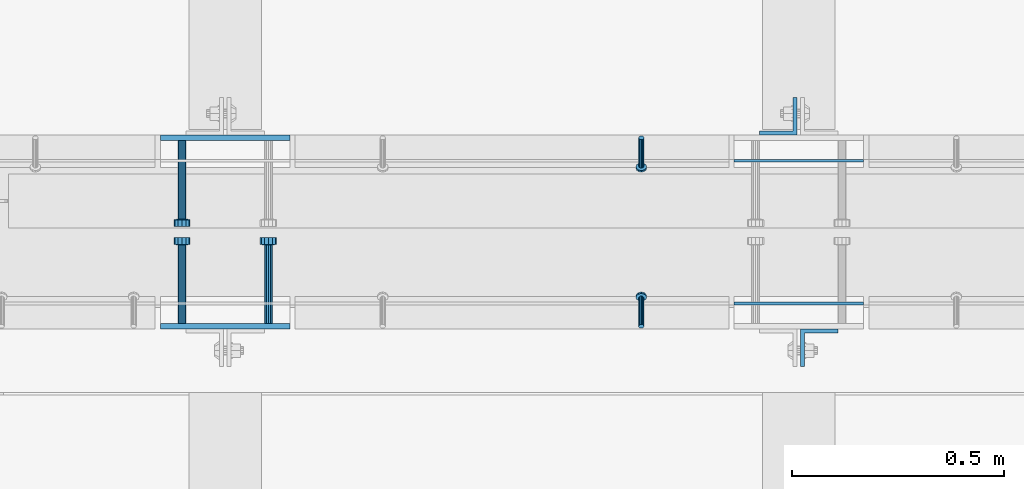
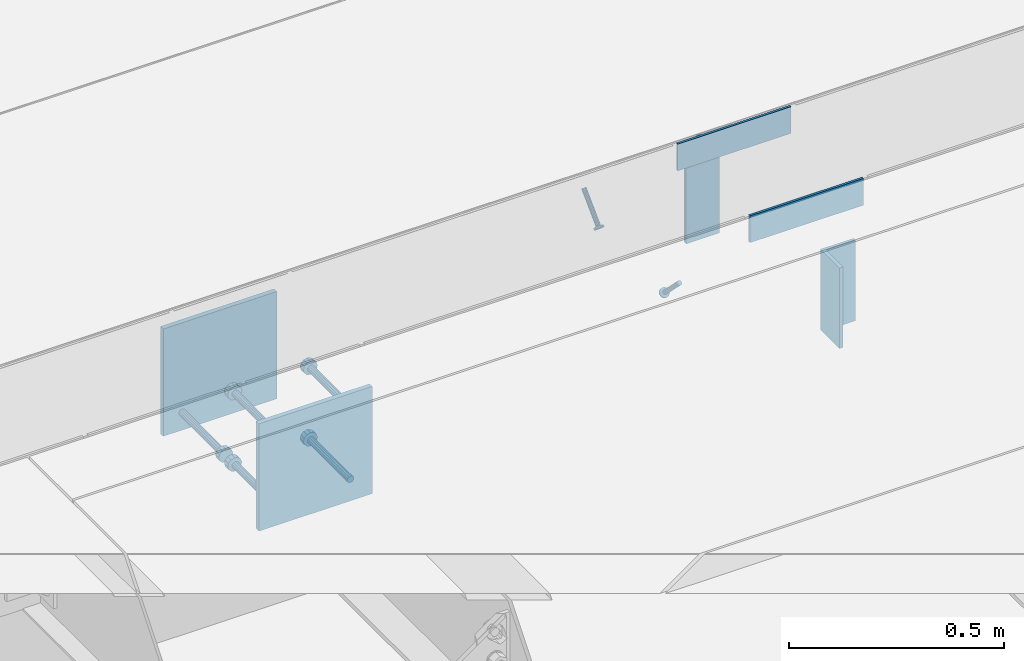
# One storey, part 2010 of 3843: 11 beams, 2 members, 8 elements without a shape of their own.
"""IFC2X3 building model written with IfcOpenShell, lengths in millimetres."""

import ifcopenshell
import ifcopenshell.guid

model = None  # the IFC model being written
_history = None  # IfcOwnerHistory: only IFC2X3 demands one
_inside = {}  # id of a spatial element -> (the spatial element, [elements in it])
_under = {}  # id of a project, library or spatial element -> (it, [spatial elements below it])
_declared = {}  # id of a project -> (the project, [libraries it declares])
_typed = {}  # id of a type object -> (the type object, [elements of that type])
_made_of = {}  # id of a material, layer set ... -> (it, [elements and type objects made of it])


def new_model(schema):
    """Start an empty IFC model of exactly this schema.

    Asked for "IFC4X3", IfcOpenShell would pick the latest addendum, in which some entities
    have other attributes; the version numbers below select the first issue.
    IFC2X3 requires an IfcOwnerHistory on every rooted entity: one is made here for all.
    """
    global model, _history
    if schema == "IFC4X3":
        model = ifcopenshell.file(schema_version=(4, 3, 0, 0))
    else:
        model = ifcopenshell.file(schema=schema)
    _inside.clear()
    _under.clear()
    _declared.clear()
    _typed.clear()
    _made_of.clear()
    _history = None
    if model.schema == "IFC2X3":
        org = make("IfcOrganization", Name="unknown")
        user = make(
            "IfcPersonAndOrganization",
            ThePerson=make("IfcPerson", FamilyName="unknown"),
            TheOrganization=org,
        )
        app = make(
            "IfcApplication",
            ApplicationDeveloper=org,
            Version="unknown",
            ApplicationFullName="unknown",
            ApplicationIdentifier="unknown",
        )
        _history = make(
            "IfcOwnerHistory",
            OwningUser=user,
            OwningApplication=app,
            ChangeAction="ADDED",
            CreationDate=0,
        )
    return model


def make(cls, **values):
    """One entity of the class cls with the attributes given. An attribute that is None is left unset."""
    return model.create_entity(
        cls, **{name: value for name, value in values.items() if value is not None}
    )


def rooted(cls, **values):
    """An entity with a GlobalId (a new one), such as an element, a storey or a relation."""
    return make(cls, GlobalId=ifcopenshell.guid.new(), OwnerHistory=_history, **values)


def si_unit(unit_type, name, prefix=None):
    """IfcSIUnit, for example si_unit("LENGTHUNIT", "METRE", prefix="MILLI")."""
    return make("IfcSIUnit", UnitType=unit_type, Prefix=prefix, Name=name)


def assignment(units):
    """IfcUnitAssignment: the units of a project."""
    return None if units is None else make("IfcUnitAssignment", Units=units)


def point(xyz):
    """IfcCartesianPoint."""
    return None if xyz is None else make("IfcCartesianPoint", Coordinates=xyz)


def direction(xyz):
    """IfcDirection."""
    return None if xyz is None else make("IfcDirection", DirectionRatios=xyz)


def frame(location, z_axis=None, x_axis=None):
    """IfcAxis2Placement3D, a coordinate frame: its origin and axes. An axis left out is left unset."""
    return make(
        "IfcAxis2Placement3D",
        Location=point(location),
        Axis=direction(z_axis),
        RefDirection=direction(x_axis),
    )


def origin_with_axes():
    """The frame at (0, 0, 0) with the z axis (0, 0, 1) and the x axis (1, 0, 0) written out."""
    return frame((0.0, 0.0, 0.0), z_axis=(0.0, 0.0, 1.0), x_axis=(1.0, 0.0, 0.0))


def place(relative_to, where):
    """IfcLocalPlacement: puts the frame where relative to a parent placement (None: the world)."""
    return make(
        "IfcLocalPlacement", PlacementRelTo=relative_to, RelativePlacement=where
    )


def context(
    kind, dimensions, precision=None, world=None, true_north=None, identifier=None
):
    """IfcGeometricRepresentationContext, for example the 3D "Model" context."""
    return make(
        "IfcGeometricRepresentationContext",
        ContextIdentifier=identifier,
        ContextType=kind,
        CoordinateSpaceDimension=dimensions,
        Precision=precision,
        WorldCoordinateSystem=world,
        TrueNorth=true_north,
    )


def subcontext(parent, identifier, kind, view, scale=None):
    """IfcGeometricRepresentationSubContext, for example "Body" below "Model"."""
    return make(
        "IfcGeometricRepresentationSubContext",
        ContextIdentifier=identifier,
        ContextType=kind,
        ParentContext=parent,
        TargetScale=scale,
        TargetView=view,
    )


def project(units=None, contexts=None):
    """IfcProject with its units and contexts."""
    return rooted(
        "IfcProject",
        Name="project",
        RepresentationContexts=contexts,
        UnitsInContext=assignment(units),
    )


def spatial(cls, under=None, at=None, **own):
    """A site, building, storey or space (cls), placed at a placement, below another one or the project."""
    s = rooted(cls, ObjectPlacement=at, **own)
    if under is not None:
        _under.setdefault(under.id(), (under, []))[1].append(s)
    return s


def faces_of(points, faces, orient=None, outer=None):
    """IfcFace entities. A face is a list of loops; a loop is a list of indices into points, from 0.

    orient and outer hold one flag for each loop. By default every Orientation is true, the
    first loop of a face is its IfcFaceOuterBound and the others are IfcFaceBound.
    """
    made = []
    for i, loops in enumerate(faces):
        bounds = []
        for j, loop in enumerate(loops):
            is_outer = j == 0 if outer is None else outer[i][j]
            bounds.append(
                make(
                    "IfcFaceOuterBound" if is_outer else "IfcFaceBound",
                    Bound=make("IfcPolyLoop", Polygon=[points[k] for k in loop]),
                    Orientation=True if orient is None else orient[i][j],
                )
            )
        made.append(make("IfcFace", Bounds=bounds))
    return made


def faceted_brep(points, faces, orient=None, outer=None, voids=None):
    """IfcFacetedBrep: a solid bounded by flat faces; with voids (closed shells), ...WithVoids."""
    shared = [point(p) for p in points]
    hull = make("IfcClosedShell", CfsFaces=faces_of(shared, faces, orient, outer))
    if voids is None:
        return make("IfcFacetedBrep", Outer=hull)
    return make(
        "IfcFacetedBrepWithVoids",
        Outer=hull,
        Voids=[
            make(cls, CfsFaces=faces_of(shared, fs, o, b)) for cls, fs, o, b in voids
        ],
    )


def shape(context_of_items, identifier, shape_type, items):
    """IfcShapeRepresentation: the items that make up one representation, for example the "Body"."""
    return make(
        "IfcShapeRepresentation",
        ContextOfItems=context_of_items,
        RepresentationIdentifier=identifier,
        RepresentationType=shape_type,
        Items=items,
    )


def material(Name=None, Category=None):
    """IfcMaterial."""
    return make("IfcMaterial", Name=Name, Category=Category)


def made_of(thing, what):
    """Note that an element or type object is made of a material, layer set ...; save() writes the relation."""
    if what is not None:
        _made_of.setdefault(what.id(), (what, []))[1].append(thing)
    return thing


def type_object(cls, material=None, **own):
    """A type object (cls), such as IfcWallType, which elements share."""
    return made_of(rooted(cls, **own), material)


def element(
    cls,
    number,
    at=None,
    inside=None,
    cuts=None,
    type_object=None,
    material=None,
    context=None,
    identifier="Body",
    shape_type=None,
    held_by="IfcProductDefinitionShape",
    body=None,
    shapes=None,
    **own,
):
    """One element of the class cls, such as IfcWall. Its Tag is "e" and its number.

    at: its placement. inside: the storey or other place that contains it. cuts: it is an
    opening in that element (IfcRelVoidsElement). A single representation is given by context,
    identifier, shape_type and body (its items); several are given by shapes. held_by: the class
    of the entity that holds the representations. save() writes the other relations.
    """
    e = rooted(cls, Tag="e%d" % number, ObjectPlacement=at, **own)
    if body is not None:
        shapes = [shape(context, identifier, shape_type, body)]
    if shapes is not None:
        e.Representation = make(held_by, Representations=shapes)
    if inside is not None:
        _inside.setdefault(inside.id(), (inside, []))[1].append(e)
    if cuts is not None:
        rooted(
            "IfcRelVoidsElement", RelatingBuildingElement=cuts, RelatedOpeningElement=e
        )
    if type_object is not None:
        _typed.setdefault(type_object.id(), (type_object, []))[1].append(e)
    return made_of(e, material)


def aggregate(whole, parts):
    """IfcRelAggregates: a whole, such as a stair, and the parts it consists of."""
    return rooted("IfcRelAggregates", RelatingObject=whole, RelatedObjects=parts)


def save(model, path):
    """Write the relations noted so far, then the file.

    IfcRelAggregates (storeys below a building ...), IfcRelContainedInSpatialStructure (elements
    in a storey), IfcRelDefinesByType, IfcRelAssociatesMaterial and IfcRelDeclares: one each for
    every whole, place, type object, material and project.
    """
    for whole, parts in _under.values():
        aggregate(whole, parts)
    for where, things in _inside.values():
        rooted(
            "IfcRelContainedInSpatialStructure",
            RelatedElements=things,
            RelatingStructure=where,
        )
    for kind, things in _typed.values():
        rooted("IfcRelDefinesByType", RelatedObjects=things, RelatingType=kind)
    for what, things in _made_of.values():
        rooted("IfcRelAssociatesMaterial", RelatedObjects=things, RelatingMaterial=what)
    for by, libraries in _declared.values():
        rooted("IfcRelDeclares", RelatingContext=by, RelatedDefinitions=libraries)
    model.write(path)


model = new_model("IFC2X3")

# Units and contexts
model_context = context("Model", 3, precision=1e-05, world=origin_with_axes())
body_context = subcontext(model_context, "Body", "Model", "MODEL_VIEW")
ifc_project = project(units=[si_unit("LENGTHUNIT", "METRE", prefix="MILLI"), si_unit("AREAUNIT", "SQUARE_METRE"), si_unit("VOLUMEUNIT", "CUBIC_METRE"), si_unit("MASSUNIT", "GRAM", prefix="KILO"), si_unit("TIMEUNIT", "SECOND"), si_unit("PLANEANGLEUNIT", "RADIAN"), si_unit("SOLIDANGLEUNIT", "STERADIAN"), si_unit("THERMODYNAMICTEMPERATUREUNIT", "DEGREE_CELSIUS"), si_unit("LUMINOUSINTENSITYUNIT", "LUMEN")], contexts=[model_context])

# Site, building, storey
site_placement = place(None, origin_with_axes())
site = spatial("IfcSite", under=ifc_project, at=site_placement, CompositionType="ELEMENT")
building_placement = place(site_placement, origin_with_axes())
building = spatial("IfcBuilding", under=site, at=building_placement, Name="Undefined", CompositionType="ELEMENT")
storey_placement = place(building_placement, origin_with_axes())
storey = spatial("IfcBuildingStorey", under=building, at=storey_placement, Name="Undefined", CompositionType="ELEMENT", Elevation=0.0)

# Assembly, member
assembly_1_placement = place(storey_placement, origin_with_axes())
assembly_1 = element("IfcElementAssembly", 1, at=assembly_1_placement, inside=storey, Name="ANGLE", AssemblyPlace="NOTDEFINED", PredefinedType="RIGID_FRAME")
ifc_material_1 = material(Name="STEEL/A108")
member_type = type_object("IfcMemberType", PredefinedType="NOTDEFINED")
member_1_placement = place(assembly_1_placement, frame((43751.5272929978, 20456.5250055596, 30397.4500030518), z_axis=(1.0, 0.0, 0.0), x_axis=(0.0, -0.707106781186548, -0.707106781186548)))
member_1 = element("IfcMember", 2, at=member_1_placement, type_object=member_type, material=ifc_material_1, Name="HEADED STUD ANCHOR", context=body_context, shape_type="Brep", body=[
    faceted_brep([(7.27595761418343e-12, -3.18000006675175, 5.5), (0.0, -5.49999999998363, 3.1800000667572), (94.4879985803855, -5.50000000011278, 3.1800000667572), (94.4879985803782, -3.18000006687362, 5.5), (0.0, -6.3499999046162, 0.0), (94.4879985803855, -6.34999990474535, 0.0), (0.0, -5.49999999998363, -3.1800000667572), (94.4879985803855, -5.50000000011278, -3.1800000667572), (7.27595761418343e-12, -3.18000006675175, -5.5), (94.4879985803782, -3.18000006687362, -5.5), (7.27595761418343e-12, -1.81898940354586e-12, -6.34999990463257), (94.4879985803782, -1.20053300634027e-10, -6.34999990463257), (0.0, 3.18000006675175, -5.5), (94.4879985803709, 3.18000006663351, -5.5), (7.27595761418343e-12, 5.49999999998363, -3.1800000667572), (94.4879985803709, 5.49999999987267, -3.1800000667572), (7.27595761418343e-12, 6.3499999046162, 0.0), (94.4879985803673, 6.34999990450706, 0.0), (7.27595761418343e-12, 5.49999999998363, 3.1800000667572), (94.4879985803709, 5.49999999987267, 3.1800000667572), (0.0, 3.18000006675175, 5.5), (94.4879985803709, 3.18000006663351, 5.5), (7.27595761418343e-12, -1.81898940354586e-12, 6.34999990463257), (94.4879985803782, -1.20053300634027e-10, 6.34999990463257), (96.5199985498621, -10.9899997712273, 6.34999990463257), (96.5199985498548, -6.34000015270249, 10.9899997711182), (96.5199985498621, -12.6999998093743, 0.0), (96.5199985498621, -10.9899997712273, -6.34999990463257), (96.5199985498548, -6.34000015270249, -10.9899997711182), (96.5199985498475, -1.21872290037572e-10, -12.6899995803833), (96.5199985498402, 6.34000015245874, -10.9899997711182), (96.519998549833, 10.9899997709817, -6.34999990463257), (96.519998549833, 12.6999998091305, 0.0), (96.519998549833, 10.9899997709817, 6.34999990463257), (96.5199985498402, 6.34000015245874, 10.9899997711182), (96.5199985498475, -1.21872290037572e-10, 12.6899995803833), (101.599998473539, -10.9899997712328, 6.34999990463257), (101.599998473532, -6.34000015270976, 10.9899997711182), (101.599998473539, -12.6999998093797, 0.0), (101.599998473539, -10.9899997712328, -6.34999990463257), (101.599998473532, -6.34000015270976, -10.9899997711182), (101.599998473524, -1.29148247651756e-10, -12.6899995803833), (101.599998473517, 6.34000015245329, -10.9899997711182), (101.59999847351, 10.9899997709763, -6.34999990463257), (101.599998473503, 12.6999998091196, 0.0), (101.59999847351, 10.9899997709763, 6.34999990463257), (101.599998473517, 6.34000015245329, 10.9899997711182), (101.599998473524, -1.29148247651756e-10, 12.6899995803833)], [[[0, 1, 2, 3]], [[1, 4, 5, 2]], [[4, 6, 7, 5]], [[6, 8, 9, 7]], [[8, 10, 11, 9]], [[10, 12, 13, 11]], [[12, 14, 15, 13]], [[14, 16, 17, 15]], [[16, 18, 19, 17]], [[18, 20, 21, 19]], [[20, 22, 23, 21]], [[22, 0, 3, 23]], [[22, 20, 18, 16, 14, 12, 10, 8, 6, 4, 1, 0]], [[3, 2, 24, 25]], [[2, 5, 26, 24]], [[5, 7, 27, 26]], [[7, 9, 28, 27]], [[9, 11, 29, 28]], [[11, 13, 30, 29]], [[13, 15, 31, 30]], [[15, 17, 32, 31]], [[17, 19, 33, 32]], [[19, 21, 34, 33]], [[21, 23, 35, 34]], [[23, 3, 25, 35]], [[25, 24, 36, 37]], [[24, 26, 38, 36]], [[26, 27, 39, 38]], [[27, 28, 40, 39]], [[28, 29, 41, 40]], [[29, 30, 42, 41]], [[30, 31, 43, 42]], [[31, 32, 44, 43]], [[32, 33, 45, 44]], [[33, 34, 46, 45]], [[34, 35, 47, 46]], [[35, 25, 37, 47]], [[38, 39, 40, 41, 42, 43, 44, 45, 46, 47, 37, 36]]]),
])
aggregate(assembly_1, [member_1])

assembly_2_placement = place(storey_placement, origin_with_axes())
assembly_2 = element("IfcElementAssembly", 3, at=assembly_2_placement, inside=storey, Name="ANGLE", AssemblyPlace="NOTDEFINED", PredefinedType="RIGID_FRAME")
member_2_placement = place(assembly_2_placement, frame((43751.4902526855, 20012.024996964, 30397.4500030518), z_axis=(-1.0, 0.0, 0.0), x_axis=(5.70000238222118e-08, 0.707106781186546, -0.707106781186546)))
member_2 = element("IfcMember", 4, at=member_2_placement, type_object=member_type, material=ifc_material_1, Name="HEADED STUD ANCHOR", context=body_context, shape_type="Brep", body=[
    faceted_brep([(7.27595761418343e-12, -3.18000006675175, 5.5), (0.0, -5.49999999998363, 3.1800000667572), (94.4879985803855, -5.50000000011278, 3.1800000667572), (94.4879985803782, -3.18000006687362, 5.5), (0.0, -6.3499999046162, 0.0), (94.4879985803855, -6.34999990474535, 0.0), (0.0, -5.49999999998363, -3.1800000667572), (94.4879985803855, -5.50000000011278, -3.1800000667572), (7.27595761418343e-12, -3.18000006675175, -5.5), (94.4879985803782, -3.18000006687362, -5.5), (7.27595761418343e-12, -1.81898940354586e-12, -6.34999990463257), (94.4879985803782, -1.20053300634027e-10, -6.34999990463257), (0.0, 3.18000006675175, -5.5), (94.4879985803709, 3.18000006663351, -5.5), (7.27595761418343e-12, 5.49999999998363, -3.1800000667572), (94.4879985803709, 5.49999999987267, -3.1800000667572), (7.27595761418343e-12, 6.3499999046162, 0.0), (94.4879985803673, 6.34999990450706, 0.0), (7.27595761418343e-12, 5.49999999998363, 3.1800000667572), (94.4879985803709, 5.49999999987267, 3.1800000667572), (0.0, 3.18000006675175, 5.5), (94.4879985803709, 3.18000006663351, 5.5), (7.27595761418343e-12, -1.81898940354586e-12, 6.34999990463257), (94.4879985803782, -1.20053300634027e-10, 6.34999990463257), (96.5199985498621, -10.9899997712273, 6.34999990463257), (96.5199985498548, -6.34000015270249, 10.9899997711182), (96.5199985498621, -12.6999998093743, 0.0), (96.5199985498621, -10.9899997712273, -6.34999990463257), (96.5199985498548, -6.34000015270249, -10.9899997711182), (96.5199985498475, -1.21872290037572e-10, -12.6899995803833), (96.5199985498402, 6.34000015245874, -10.9899997711182), (96.519998549833, 10.9899997709817, -6.34999990463257), (96.519998549833, 12.6999998091305, 0.0), (96.519998549833, 10.9899997709817, 6.34999990463257), (96.5199985498402, 6.34000015245874, 10.9899997711182), (96.5199985498475, -1.21872290037572e-10, 12.6899995803833), (101.599998473539, -10.9899997712328, 6.34999990463257), (101.599998473532, -6.34000015270976, 10.9899997711182), (101.599998473539, -12.6999998093797, 0.0), (101.599998473539, -10.9899997712328, -6.34999990463257), (101.599998473532, -6.34000015270976, -10.9899997711182), (101.599998473524, -1.29148247651756e-10, -12.6899995803833), (101.599998473517, 6.34000015245329, -10.9899997711182), (101.59999847351, 10.9899997709763, -6.34999990463257), (101.599998473503, 12.6999998091196, 0.0), (101.59999847351, 10.9899997709763, 6.34999990463257), (101.599998473517, 6.34000015245329, 10.9899997711182), (101.599998473524, -1.29148247651756e-10, 12.6899995803833)], [[[0, 1, 2, 3]], [[1, 4, 5, 2]], [[4, 6, 7, 5]], [[6, 8, 9, 7]], [[8, 10, 11, 9]], [[10, 12, 13, 11]], [[12, 14, 15, 13]], [[14, 16, 17, 15]], [[16, 18, 19, 17]], [[18, 20, 21, 19]], [[20, 22, 23, 21]], [[22, 0, 3, 23]], [[22, 20, 18, 16, 14, 12, 10, 8, 6, 4, 1, 0]], [[3, 2, 24, 25]], [[2, 5, 26, 24]], [[5, 7, 27, 26]], [[7, 9, 28, 27]], [[9, 11, 29, 28]], [[11, 13, 30, 29]], [[13, 15, 31, 30]], [[15, 17, 32, 31]], [[17, 19, 33, 32]], [[19, 21, 34, 33]], [[21, 23, 35, 34]], [[23, 3, 25, 35]], [[25, 24, 36, 37]], [[24, 26, 38, 36]], [[26, 27, 39, 38]], [[27, 28, 40, 39]], [[28, 29, 41, 40]], [[29, 30, 42, 41]], [[30, 31, 43, 42]], [[31, 32, 44, 43]], [[32, 33, 45, 44]], [[33, 34, 46, 45]], [[34, 35, 47, 46]], [[35, 25, 37, 47]], [[38, 39, 40, 41, 42, 43, 44, 45, 46, 47, 37, 36]]]),
])
aggregate(assembly_2, [member_2])

# Assembly, beam
assembly_3_placement = place(storey_placement, origin_with_axes())
assembly_3 = element("IfcElementAssembly", 5, at=assembly_3_placement, inside=storey, Name="EMBED PLATE", AssemblyPlace="NOTDEFINED", PredefinedType="RIGID_FRAME")
ifc_material_2 = material(Name="STEEL/A36")
beam_type_1 = type_object("IfcBeamType", PredefinedType="NOTDEFINED")
beam_1_placement = place(assembly_3_placement, frame((43970.575, 20065.9999969482, 30441.9), z_axis=(0.0, 0.0, 1.0), x_axis=(1.0, 0.0, 0.0)))
beam_1 = element("IfcBeam", 6, at=beam_1_placement, type_object=beam_type_1, material=ifc_material_2, Name="PLATE", context=body_context, shape_type="Brep", body=[
    faceted_brep([(0.0, 3.17500000000291, -38.0999999999985), (0.0, 3.17500000000291, 38.0999999999985), (304.800000000003, 3.17499999999927, 38.0999999999985), (304.800000000003, 3.17499999999927, -38.0999999999985), (0.0, -3.17500000000291, 38.0999999999985), (304.800000000003, -3.17499999999927, 38.0999999999985), (0.0, -3.17500000000291, -38.0999999999985), (304.800000000003, -3.17499999999927, -38.0999999999985)], [[[0, 1, 2, 3]], [[1, 4, 5, 2]], [[4, 6, 7, 5]], [[6, 0, 3, 7]], [[5, 7, 3, 2]], [[6, 4, 1, 0]]]),
])
aggregate(assembly_3, [beam_1])

assembly_4_placement = place(storey_placement, origin_with_axes())
assembly_4 = element("IfcElementAssembly", 7, at=assembly_4_placement, inside=storey, Name="EMBED PLATE", AssemblyPlace="NOTDEFINED", PredefinedType="RIGID_FRAME")
beam_2_placement = place(assembly_4_placement, frame((44275.375, 20402.5500030518, 30441.9), z_axis=(0.0, 0.0, 1.0), x_axis=(-1.0, 0.0, 0.0)))
beam_2 = element("IfcBeam", 8, at=beam_2_placement, type_object=beam_type_1, material=ifc_material_2, Name="PLATE", context=body_context, shape_type="Brep", body=[
    faceted_brep([(0.0, 3.17500000000291, -38.0999999999985), (0.0, 3.17500000000291, 38.0999999999985), (304.800000000003, 3.17499999999927, 38.0999999999985), (304.800000000003, 3.17499999999927, -38.0999999999985), (0.0, -3.17500000000291, 38.0999999999985), (304.800000000003, -3.17499999999927, 38.0999999999985), (0.0, -3.17500000000291, -38.0999999999985), (304.800000000003, -3.17499999999927, -38.0999999999985)], [[[0, 1, 2, 3]], [[1, 4, 5, 2]], [[4, 6, 7, 5]], [[6, 0, 3, 7]], [[5, 7, 3, 2]], [[6, 4, 1, 0]]]),
])
aggregate(assembly_4, [beam_2])

assembly_5_placement = place(storey_placement, origin_with_axes())
assembly_5 = element("IfcElementAssembly", 9, at=assembly_5_placement, inside=storey, Name="EMBED PLATE", AssemblyPlace="NOTDEFINED", PredefinedType="RIGID_FRAME")
beam_type_2 = type_object("IfcBeamType", PredefinedType="NOTDEFINED")
beam_3_placement = place(assembly_5_placement, frame((42770.425, 20456.5250030518, 30397.45), z_axis=(-1.0, 0.0, 0.0), x_axis=(0.0, 0.0, -1.0)))
beam_3 = element("IfcBeam", 10, at=beam_3_placement, type_object=beam_type_2, material=ifc_material_2, Name="EMBED PLATE", context=body_context, shape_type="Brep", body=[
    faceted_brep([(-1.0550138540566e-10, 6.34999999999854, -152.400000000664), (1.0550138540566e-10, 6.34999999999854, 152.400000000656), (304.799999999999, 6.34999999999854, 152.400000000001), (304.799999999999, 6.34999999999854, -152.400000000001), (1.0550138540566e-10, -6.34999999999854, 152.400000000656), (304.799999999999, -6.34999999999854, 152.400000000001), (-1.0550138540566e-10, -6.34999999999854, -152.400000000664), (304.799999999999, -6.34999999999854, -152.400000000001)], [[[0, 1, 2, 3]], [[1, 4, 5, 2]], [[4, 6, 7, 5]], [[6, 0, 3, 7]], [[5, 7, 3, 2]], [[6, 4, 1, 0]]]),
])

assembly_6_placement = place(storey_placement, origin_with_axes())
assembly_6 = element("IfcElementAssembly", 11, at=assembly_6_placement, inside=storey, Name="EMBED PLATE", AssemblyPlace="NOTDEFINED", PredefinedType="RIGID_FRAME")
beam_4_placement = place(assembly_6_placement, frame((42770.425, 20012.0249969482, 30397.45), z_axis=(1.0, 0.0, 0.0), x_axis=(0.0, 0.0, -1.0)))
beam_4 = element("IfcBeam", 12, at=beam_4_placement, type_object=beam_type_2, material=ifc_material_2, Name="EMBED PLATE", context=body_context, shape_type="Brep", body=[
    faceted_brep([(-1.0550138540566e-10, 6.34999999999854, -152.400000000664), (1.0550138540566e-10, 6.34999999999854, 152.400000000656), (304.799999999999, 6.34999999999854, 152.400000000001), (304.799999999999, 6.34999999999854, -152.400000000001), (1.0550138540566e-10, -6.34999999999854, 152.400000000656), (304.799999999999, -6.34999999999854, 152.400000000001), (-1.0550138540566e-10, -6.34999999999854, -152.400000000664), (304.799999999999, -6.34999999999854, -152.400000000001)], [[[0, 1, 2, 3]], [[1, 4, 5, 2]], [[4, 6, 7, 5]], [[6, 0, 3, 7]], [[5, 7, 3, 2]], [[6, 4, 1, 0]]]),
])

assembly_7_placement = place(storey_placement, origin_with_axes())
assembly_7 = element("IfcElementAssembly", 13, at=assembly_7_placement, inside=storey, Name="BEAM", AssemblyPlace="NOTDEFINED", PredefinedType="RIGID_FRAME")
beam_type_3 = type_object("IfcBeamType", Name="L3-1/2X3-1/2X3/8", PredefinedType="NOTDEFINED")
beam_5_placement = place(assembly_7_placement, frame((44074.55625, 20507.3250030517, 30365.7), z_axis=(-1.0, 0.0, 0.0), x_axis=(0.0, 0.0, -1.0)))
beam_5 = element("IfcBeam", 14, at=beam_5_placement, type_object=beam_type_3, material=ifc_material_2, Name="ANGLE", ObjectType="L3-1/2X3-1/2X3/8", context=body_context, shape_type="Brep", body=[
    faceted_brep([(-3.63797880709171e-12, 44.4499999999971, -44.4500000000007), (-3.63797880709171e-12, 44.4499999999971, 44.4500000000007), (228.600000000006, 44.4499999999971, 44.4500000000007), (228.600000000006, 44.4499999999971, -44.4500000000007), (0.0, 34.9250000000029, 44.4500000000007), (228.600000000006, 34.9250000000029, 44.4500000000007), (0.0, 34.9250000000029, -34.9250000000029), (228.600000000006, 34.9250000000029, -34.9249999999993), (0.0, -44.4499999999971, -34.9249999999993), (228.600000000006, -44.4499999999971, -34.9249999999993), (3.63797880709171e-12, -44.4499999999971, -44.4500000000007), (228.600000000006, -44.4499999999971, -44.4500000000007)], [[[0, 1, 2, 3]], [[1, 4, 5, 2]], [[4, 6, 7, 5]], [[6, 8, 9, 7]], [[8, 10, 11, 9]], [[10, 0, 3, 11]], [[5, 7, 9, 11, 3, 2]], [[10, 8, 6, 4, 1, 0]]]),
])
aggregate(assembly_7, [beam_5])

assembly_8_placement = place(storey_placement, origin_with_axes())
assembly_8 = element("IfcElementAssembly", 15, at=assembly_8_placement, inside=storey, Name="BEAM", AssemblyPlace="NOTDEFINED", PredefinedType="RIGID_FRAME")
beam_6_placement = place(assembly_8_placement, frame((44171.39375, 19961.2249969482, 30365.7), z_axis=(1.0, 0.0, 0.0), x_axis=(0.0, 0.0, -1.0)))
beam_6 = element("IfcBeam", 16, at=beam_6_placement, type_object=beam_type_3, material=ifc_material_2, Name="ANGLE", ObjectType="L3-1/2X3-1/2X3/8", context=body_context, shape_type="Brep", body=[
    faceted_brep([(-3.63797880709171e-12, 44.4499999999971, -44.4500000000007), (-3.63797880709171e-12, 44.4499999999971, 44.4500000000007), (228.600000000006, 44.4499999999971, 44.4500000000007), (228.600000000006, 44.4499999999971, -44.4500000000007), (0.0, 34.9250000000029, 44.4500000000007), (228.600000000006, 34.9250000000029, 44.4500000000007), (0.0, 34.9250000000029, -34.9250000000029), (228.600000000006, 34.9250000000029, -34.9249999999993), (0.0, -44.4499999999971, -34.9249999999993), (228.600000000006, -44.4499999999971, -34.9249999999993), (3.63797880709171e-12, -44.4499999999971, -44.4500000000007), (228.600000000006, -44.4499999999971, -44.4500000000007)], [[[0, 1, 2, 3]], [[1, 4, 5, 2]], [[4, 6, 7, 5]], [[6, 8, 9, 7]], [[8, 10, 11, 9]], [[10, 0, 3, 11]], [[5, 7, 9, 11, 3, 2]], [[10, 8, 6, 4, 1, 0]]]),
])
aggregate(assembly_8, [beam_6])

# Beam
beam_type_4 = type_object("IfcBeamType", PredefinedType="NOTDEFINED")
beam_7_placement = place(assembly_5_placement, frame((42668.825, 20450.1750030518, 30143.45), z_axis=(1.0, 0.0, 0.0), x_axis=(0.0, -1.0, 0.0)))
beam_7 = element("IfcBeam", 17, at=beam_7_placement, type_object=beam_type_4, material=ifc_material_1, Name="HEADED STUD ANCHOR", context=body_context, shape_type="Brep", body=[
    faceted_brep([(0.0, -9.52000045776367, 0.0), (0.0, -8.25, -4.76000022888184), (184.912000000004, -8.25, -4.76000022888184), (184.912000000004, -9.52000045776367, 0.0), (0.0, -4.76000022888184, -8.25), (184.912000000004, -4.76000022888184, -8.25), (0.0, 0.0, -9.52000045776367), (184.912000000004, 0.0, -9.52000045776367), (0.0, 4.76000022888184, -8.25), (184.912000000004, 4.76000022888184, -8.25), (0.0, 8.25, -4.76000022888184), (184.912000000004, 8.25, -4.76000022888184), (0.0, 9.52000045776367, 0.0), (184.912000000004, 9.52000045776367, 0.0), (0.0, 8.25, 4.76000022888184), (184.912000000004, 8.25, 4.76000022888184), (0.0, 4.76000022888184, 8.25), (184.912000000004, 4.76000022888184, 8.25), (0.0, 0.0, 9.52000045776367), (184.912000000004, 0.0, 9.52000045776367), (0.0, -4.76000022888184, 8.25), (184.912000000004, -4.76000022888184, 8.25), (0.0, -8.25, 4.76000022888184), (184.912000000004, -8.25, 4.76000022888184), (186.944000000003, -16.5, -9.52000045776367), (186.944000000003, -19.0499992370605, 0.0), (186.944000000003, -9.52000045776367, -16.5), (186.944000000003, 0.0, -19.0499992370605), (186.944000000003, 9.52000045776367, -16.5), (186.944000000003, 16.5, -9.52000045776367), (186.944000000003, 19.0499992370605, 0.0), (186.944000000003, 16.5, 9.52000045776367), (186.944000000003, 9.52000045776367, 16.5), (186.944000000003, 0.0, 19.0499992370605), (186.944000000003, -9.52000045776367, 16.5), (186.944000000003, -16.5, 9.52000045776367), (203.199999999997, -16.5, -9.52000045776367), (203.199999999997, -19.0499992370605, 0.0), (203.199999999997, -9.52000045776367, -16.5), (203.199999999997, 0.0, -19.0499992370605), (203.199999999997, 9.52000045776367, -16.5), (203.199999999997, 16.5, -9.52000045776367), (203.199999999997, 19.0499992370605, 0.0), (203.199999999997, 16.5, 9.52000045776367), (203.199999999997, 9.52000045776367, 16.5), (203.199999999997, 0.0, 19.0499992370605), (203.199999999997, -9.52000045776367, 16.5), (203.199999999997, -16.5, 9.52000045776367)], [[[0, 1, 2, 3]], [[1, 4, 5, 2]], [[4, 6, 7, 5]], [[6, 8, 9, 7]], [[8, 10, 11, 9]], [[10, 12, 13, 11]], [[12, 14, 15, 13]], [[14, 16, 17, 15]], [[16, 18, 19, 17]], [[18, 20, 21, 19]], [[20, 22, 23, 21]], [[22, 0, 3, 23]], [[22, 20, 18, 16, 14, 12, 10, 8, 6, 4, 1, 0]], [[3, 2, 24, 25]], [[2, 5, 26, 24]], [[5, 7, 27, 26]], [[7, 9, 28, 27]], [[9, 11, 29, 28]], [[11, 13, 30, 29]], [[13, 15, 31, 30]], [[15, 17, 32, 31]], [[17, 19, 33, 32]], [[19, 21, 34, 33]], [[21, 23, 35, 34]], [[23, 3, 25, 35]], [[25, 24, 36, 37]], [[24, 26, 38, 36]], [[26, 27, 39, 38]], [[27, 28, 40, 39]], [[28, 29, 41, 40]], [[29, 30, 42, 41]], [[30, 31, 43, 42]], [[31, 32, 44, 43]], [[32, 33, 45, 44]], [[33, 34, 46, 45]], [[34, 35, 47, 46]], [[35, 25, 37, 47]], [[38, 39, 40, 41, 42, 43, 44, 45, 46, 47, 37, 36]]]),
])

aggregate(assembly_5, [beam_7, beam_3])

beam_8_placement = place(assembly_6_placement, frame((42668.825, 20018.3749969482, 30346.65), z_axis=(-1.0, 0.0, 0.0), x_axis=(0.0, 1.0, 0.0)))
beam_8 = element("IfcBeam", 18, at=beam_8_placement, type_object=beam_type_4, material=ifc_material_1, Name="HEADED STUD ANCHOR", context=body_context, shape_type="Brep", body=[
    faceted_brep([(0.0, -9.52000045776367, 0.0), (0.0, -8.25, -4.76000022888184), (184.912000000004, -8.25, -4.76000022888184), (184.912000000004, -9.52000045776367, 0.0), (0.0, -4.76000022888184, -8.25), (184.912000000004, -4.76000022888184, -8.25), (0.0, 0.0, -9.52000045776367), (184.912000000004, 0.0, -9.52000045776367), (0.0, 4.76000022888184, -8.25), (184.912000000004, 4.76000022888184, -8.25), (0.0, 8.25, -4.76000022888184), (184.912000000004, 8.25, -4.76000022888184), (0.0, 9.52000045776367, 0.0), (184.912000000004, 9.52000045776367, 0.0), (0.0, 8.25, 4.76000022888184), (184.912000000004, 8.25, 4.76000022888184), (0.0, 4.76000022888184, 8.25), (184.912000000004, 4.76000022888184, 8.25), (0.0, 0.0, 9.52000045776367), (184.912000000004, 0.0, 9.52000045776367), (0.0, -4.76000022888184, 8.25), (184.912000000004, -4.76000022888184, 8.25), (0.0, -8.25, 4.76000022888184), (184.912000000004, -8.25, 4.76000022888184), (186.944000000003, -16.5, -9.52000045776367), (186.944000000003, -19.0499992370605, 0.0), (186.944000000003, -9.52000045776367, -16.5), (186.944000000003, 0.0, -19.0499992370605), (186.944000000003, 9.52000045776367, -16.5), (186.944000000003, 16.5, -9.52000045776367), (186.944000000003, 19.0499992370605, 0.0), (186.944000000003, 16.5, 9.52000045776367), (186.944000000003, 9.52000045776367, 16.5), (186.944000000003, 0.0, 19.0499992370605), (186.944000000003, -9.52000045776367, 16.5), (186.944000000003, -16.5, 9.52000045776367), (203.199999999997, -16.5, -9.52000045776367), (203.199999999997, -19.0499992370605, 0.0), (203.199999999997, -9.52000045776367, -16.5), (203.199999999997, 0.0, -19.0499992370605), (203.199999999997, 9.52000045776367, -16.5), (203.199999999997, 16.5, -9.52000045776367), (203.199999999997, 19.0499992370605, 0.0), (203.199999999997, 16.5, 9.52000045776367), (203.199999999997, 9.52000045776367, 16.5), (203.199999999997, 0.0, 19.0499992370605), (203.199999999997, -9.52000045776367, 16.5), (203.199999999997, -16.5, 9.52000045776367)], [[[0, 1, 2, 3]], [[1, 4, 5, 2]], [[4, 6, 7, 5]], [[6, 8, 9, 7]], [[8, 10, 11, 9]], [[10, 12, 13, 11]], [[12, 14, 15, 13]], [[14, 16, 17, 15]], [[16, 18, 19, 17]], [[18, 20, 21, 19]], [[20, 22, 23, 21]], [[22, 0, 3, 23]], [[22, 20, 18, 16, 14, 12, 10, 8, 6, 4, 1, 0]], [[3, 2, 24, 25]], [[2, 5, 26, 24]], [[5, 7, 27, 26]], [[7, 9, 28, 27]], [[9, 11, 29, 28]], [[11, 13, 30, 29]], [[13, 15, 31, 30]], [[15, 17, 32, 31]], [[17, 19, 33, 32]], [[19, 21, 34, 33]], [[21, 23, 35, 34]], [[23, 3, 25, 35]], [[25, 24, 36, 37]], [[24, 26, 38, 36]], [[26, 27, 39, 38]], [[27, 28, 40, 39]], [[28, 29, 41, 40]], [[29, 30, 42, 41]], [[30, 31, 43, 42]], [[31, 32, 44, 43]], [[32, 33, 45, 44]], [[33, 34, 46, 45]], [[34, 35, 47, 46]], [[35, 25, 37, 47]], [[38, 39, 40, 41, 42, 43, 44, 45, 46, 47, 37, 36]]]),
])

beam_9_placement = place(assembly_6_placement, frame((42668.825, 20018.3749969482, 30143.45), z_axis=(-1.0, 0.0, 0.0), x_axis=(0.0, 1.0, 0.0)))
beam_9 = element("IfcBeam", 19, at=beam_9_placement, type_object=beam_type_4, material=ifc_material_1, Name="HEADED STUD ANCHOR", context=body_context, shape_type="Brep", body=[
    faceted_brep([(0.0, -9.52000045776367, 0.0), (0.0, -8.25, -4.76000022888184), (184.912000000004, -8.25, -4.76000022888184), (184.912000000004, -9.52000045776367, 0.0), (0.0, -4.76000022888184, -8.25), (184.912000000004, -4.76000022888184, -8.25), (0.0, 0.0, -9.52000045776367), (184.912000000004, 0.0, -9.52000045776367), (0.0, 4.76000022888184, -8.25), (184.912000000004, 4.76000022888184, -8.25), (0.0, 8.25, -4.76000022888184), (184.912000000004, 8.25, -4.76000022888184), (0.0, 9.52000045776367, 0.0), (184.912000000004, 9.52000045776367, 0.0), (0.0, 8.25, 4.76000022888184), (184.912000000004, 8.25, 4.76000022888184), (0.0, 4.76000022888184, 8.25), (184.912000000004, 4.76000022888184, 8.25), (0.0, 0.0, 9.52000045776367), (184.912000000004, 0.0, 9.52000045776367), (0.0, -4.76000022888184, 8.25), (184.912000000004, -4.76000022888184, 8.25), (0.0, -8.25, 4.76000022888184), (184.912000000004, -8.25, 4.76000022888184), (186.944000000003, -16.5, -9.52000045776367), (186.944000000003, -19.0499992370605, 0.0), (186.944000000003, -9.52000045776367, -16.5), (186.944000000003, 0.0, -19.0499992370605), (186.944000000003, 9.52000045776367, -16.5), (186.944000000003, 16.5, -9.52000045776367), (186.944000000003, 19.0499992370605, 0.0), (186.944000000003, 16.5, 9.52000045776367), (186.944000000003, 9.52000045776367, 16.5), (186.944000000003, 0.0, 19.0499992370605), (186.944000000003, -9.52000045776367, 16.5), (186.944000000003, -16.5, 9.52000045776367), (203.199999999997, -16.5, -9.52000045776367), (203.199999999997, -19.0499992370605, 0.0), (203.199999999997, -9.52000045776367, -16.5), (203.199999999997, 0.0, -19.0499992370605), (203.199999999997, 9.52000045776367, -16.5), (203.199999999997, 16.5, -9.52000045776367), (203.199999999997, 19.0499992370605, 0.0), (203.199999999997, 16.5, 9.52000045776367), (203.199999999997, 9.52000045776367, 16.5), (203.199999999997, 0.0, 19.0499992370605), (203.199999999997, -9.52000045776367, 16.5), (203.199999999997, -16.5, 9.52000045776367)], [[[0, 1, 2, 3]], [[1, 4, 5, 2]], [[4, 6, 7, 5]], [[6, 8, 9, 7]], [[8, 10, 11, 9]], [[10, 12, 13, 11]], [[12, 14, 15, 13]], [[14, 16, 17, 15]], [[16, 18, 19, 17]], [[18, 20, 21, 19]], [[20, 22, 23, 21]], [[22, 0, 3, 23]], [[22, 20, 18, 16, 14, 12, 10, 8, 6, 4, 1, 0]], [[3, 2, 24, 25]], [[2, 5, 26, 24]], [[5, 7, 27, 26]], [[7, 9, 28, 27]], [[9, 11, 29, 28]], [[11, 13, 30, 29]], [[13, 15, 31, 30]], [[15, 17, 32, 31]], [[17, 19, 33, 32]], [[19, 21, 34, 33]], [[21, 23, 35, 34]], [[23, 3, 25, 35]], [[25, 24, 36, 37]], [[24, 26, 38, 36]], [[26, 27, 39, 38]], [[27, 28, 40, 39]], [[28, 29, 41, 40]], [[29, 30, 42, 41]], [[30, 31, 43, 42]], [[31, 32, 44, 43]], [[32, 33, 45, 44]], [[33, 34, 46, 45]], [[34, 35, 47, 46]], [[35, 25, 37, 47]], [[38, 39, 40, 41, 42, 43, 44, 45, 46, 47, 37, 36]]]),
])

beam_10_placement = place(assembly_6_placement, frame((42872.025, 20018.3749969482, 30346.65), z_axis=(-1.0, 0.0, 0.0), x_axis=(0.0, 1.0, 0.0)))
beam_10 = element("IfcBeam", 20, at=beam_10_placement, type_object=beam_type_4, material=ifc_material_2, Name="PLATE", context=body_context, shape_type="Brep", body=[
    faceted_brep([(0.0, -9.52000045776367, 0.0), (0.0, -8.25, -4.76000022888184), (184.912000000004, -8.25, -4.76000022888184), (184.912000000004, -9.52000045776367, 0.0), (0.0, -4.76000022888184, -8.25), (184.912000000004, -4.76000022888184, -8.25), (0.0, 0.0, -9.52000045776367), (184.912000000004, 0.0, -9.52000045776367), (0.0, 4.76000022888184, -8.25), (184.912000000004, 4.76000022888184, -8.25), (0.0, 8.25, -4.76000022888184), (184.912000000004, 8.25, -4.76000022888184), (0.0, 9.52000045776367, 0.0), (184.912000000004, 9.52000045776367, 0.0), (0.0, 8.25, 4.76000022888184), (184.912000000004, 8.25, 4.76000022888184), (0.0, 4.76000022888184, 8.25), (184.912000000004, 4.76000022888184, 8.25), (0.0, 0.0, 9.52000045776367), (184.912000000004, 0.0, 9.52000045776367), (0.0, -4.76000022888184, 8.25), (184.912000000004, -4.76000022888184, 8.25), (0.0, -8.25, 4.76000022888184), (184.912000000004, -8.25, 4.76000022888184), (186.944000000003, -16.5, -9.52000045776367), (186.944000000003, -19.0499992370605, 0.0), (186.944000000003, -9.52000045776367, -16.5), (186.944000000003, 0.0, -19.0499992370605), (186.944000000003, 9.52000045776367, -16.5), (186.944000000003, 16.5, -9.52000045776367), (186.944000000003, 19.0499992370605, 0.0), (186.944000000003, 16.5, 9.52000045776367), (186.944000000003, 9.52000045776367, 16.5), (186.944000000003, 0.0, 19.0499992370605), (186.944000000003, -9.52000045776367, 16.5), (186.944000000003, -16.5, 9.52000045776367), (203.199999999997, -16.5, -9.52000045776367), (203.199999999997, -19.0499992370605, 0.0), (203.199999999997, -9.52000045776367, -16.5), (203.199999999997, 0.0, -19.0499992370605), (203.199999999997, 9.52000045776367, -16.5), (203.199999999997, 16.5, -9.52000045776367), (203.199999999997, 19.0499992370605, 0.0), (203.199999999997, 16.5, 9.52000045776367), (203.199999999997, 9.52000045776367, 16.5), (203.199999999997, 0.0, 19.0499992370605), (203.199999999997, -9.52000045776367, 16.5), (203.199999999997, -16.5, 9.52000045776367)], [[[0, 1, 2, 3]], [[1, 4, 5, 2]], [[4, 6, 7, 5]], [[6, 8, 9, 7]], [[8, 10, 11, 9]], [[10, 12, 13, 11]], [[12, 14, 15, 13]], [[14, 16, 17, 15]], [[16, 18, 19, 17]], [[18, 20, 21, 19]], [[20, 22, 23, 21]], [[22, 0, 3, 23]], [[22, 20, 18, 16, 14, 12, 10, 8, 6, 4, 1, 0]], [[3, 2, 24, 25]], [[2, 5, 26, 24]], [[5, 7, 27, 26]], [[7, 9, 28, 27]], [[9, 11, 29, 28]], [[11, 13, 30, 29]], [[13, 15, 31, 30]], [[15, 17, 32, 31]], [[17, 19, 33, 32]], [[19, 21, 34, 33]], [[21, 23, 35, 34]], [[23, 3, 25, 35]], [[25, 24, 36, 37]], [[24, 26, 38, 36]], [[26, 27, 39, 38]], [[27, 28, 40, 39]], [[28, 29, 41, 40]], [[29, 30, 42, 41]], [[30, 31, 43, 42]], [[31, 32, 44, 43]], [[32, 33, 45, 44]], [[33, 34, 46, 45]], [[34, 35, 47, 46]], [[35, 25, 37, 47]], [[38, 39, 40, 41, 42, 43, 44, 45, 46, 47, 37, 36]]]),
])

beam_11_placement = place(assembly_6_placement, frame((42872.025, 20018.3749969482, 30143.45), z_axis=(-1.0, 0.0, 0.0), x_axis=(0.0, 1.0, 0.0)))
beam_11 = element("IfcBeam", 21, at=beam_11_placement, type_object=beam_type_4, material=ifc_material_1, Name="HEADED STUD ANCHOR", context=body_context, shape_type="Brep", body=[
    faceted_brep([(0.0, -9.52000045776367, 0.0), (0.0, -8.25, -4.76000022888184), (184.912000000004, -8.25, -4.76000022888184), (184.912000000004, -9.52000045776367, 0.0), (0.0, -4.76000022888184, -8.25), (184.912000000004, -4.76000022888184, -8.25), (0.0, 0.0, -9.52000045776367), (184.912000000004, 0.0, -9.52000045776367), (0.0, 4.76000022888184, -8.25), (184.912000000004, 4.76000022888184, -8.25), (0.0, 8.25, -4.76000022888184), (184.912000000004, 8.25, -4.76000022888184), (0.0, 9.52000045776367, 0.0), (184.912000000004, 9.52000045776367, 0.0), (0.0, 8.25, 4.76000022888184), (184.912000000004, 8.25, 4.76000022888184), (0.0, 4.76000022888184, 8.25), (184.912000000004, 4.76000022888184, 8.25), (0.0, 0.0, 9.52000045776367), (184.912000000004, 0.0, 9.52000045776367), (0.0, -4.76000022888184, 8.25), (184.912000000004, -4.76000022888184, 8.25), (0.0, -8.25, 4.76000022888184), (184.912000000004, -8.25, 4.76000022888184), (186.944000000003, -16.5, -9.52000045776367), (186.944000000003, -19.0499992370605, 0.0), (186.944000000003, -9.52000045776367, -16.5), (186.944000000003, 0.0, -19.0499992370605), (186.944000000003, 9.52000045776367, -16.5), (186.944000000003, 16.5, -9.52000045776367), (186.944000000003, 19.0499992370605, 0.0), (186.944000000003, 16.5, 9.52000045776367), (186.944000000003, 9.52000045776367, 16.5), (186.944000000003, 0.0, 19.0499992370605), (186.944000000003, -9.52000045776367, 16.5), (186.944000000003, -16.5, 9.52000045776367), (203.199999999997, -16.5, -9.52000045776367), (203.199999999997, -19.0499992370605, 0.0), (203.199999999997, -9.52000045776367, -16.5), (203.199999999997, 0.0, -19.0499992370605), (203.199999999997, 9.52000045776367, -16.5), (203.199999999997, 16.5, -9.52000045776367), (203.199999999997, 19.0499992370605, 0.0), (203.199999999997, 16.5, 9.52000045776367), (203.199999999997, 9.52000045776367, 16.5), (203.199999999997, 0.0, 19.0499992370605), (203.199999999997, -9.52000045776367, 16.5), (203.199999999997, -16.5, 9.52000045776367)], [[[0, 1, 2, 3]], [[1, 4, 5, 2]], [[4, 6, 7, 5]], [[6, 8, 9, 7]], [[8, 10, 11, 9]], [[10, 12, 13, 11]], [[12, 14, 15, 13]], [[14, 16, 17, 15]], [[16, 18, 19, 17]], [[18, 20, 21, 19]], [[20, 22, 23, 21]], [[22, 0, 3, 23]], [[22, 20, 18, 16, 14, 12, 10, 8, 6, 4, 1, 0]], [[3, 2, 24, 25]], [[2, 5, 26, 24]], [[5, 7, 27, 26]], [[7, 9, 28, 27]], [[9, 11, 29, 28]], [[11, 13, 30, 29]], [[13, 15, 31, 30]], [[15, 17, 32, 31]], [[17, 19, 33, 32]], [[19, 21, 34, 33]], [[21, 23, 35, 34]], [[23, 3, 25, 35]], [[25, 24, 36, 37]], [[24, 26, 38, 36]], [[26, 27, 39, 38]], [[27, 28, 40, 39]], [[28, 29, 41, 40]], [[29, 30, 42, 41]], [[30, 31, 43, 42]], [[31, 32, 44, 43]], [[32, 33, 45, 44]], [[33, 34, 46, 45]], [[34, 35, 47, 46]], [[35, 25, 37, 47]], [[38, 39, 40, 41, 42, 43, 44, 45, 46, 47, 37, 36]]]),
])

aggregate(assembly_6, [beam_8, beam_9, beam_10, beam_11, beam_4])

save(model, "model.ifc")
